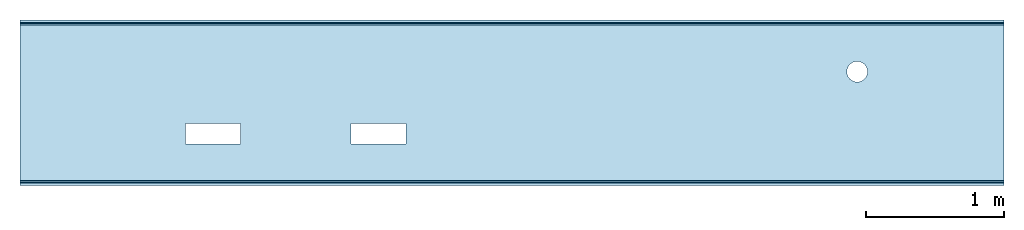
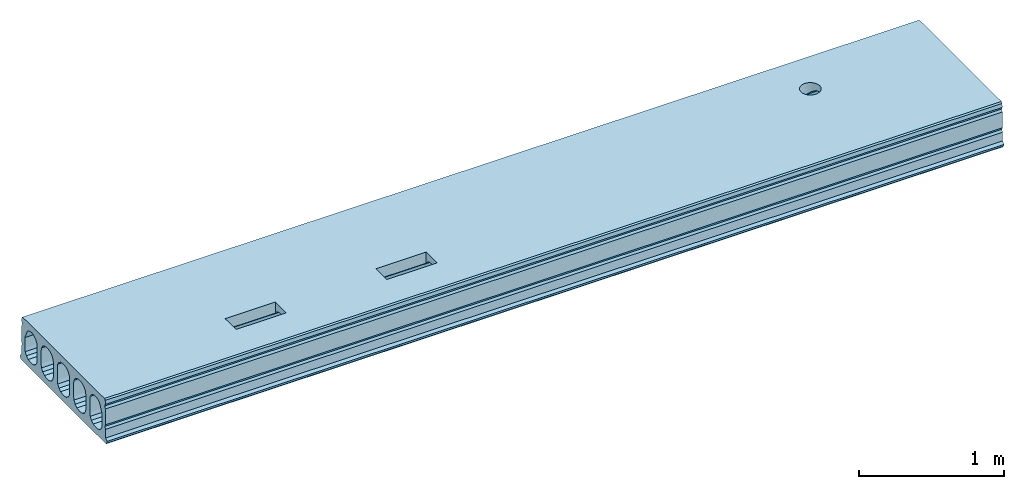
# One storey: 1 slab.
"""IFC2X3 building model written with IfcOpenShell, lengths in millimetres."""

from ifc_helpers import new_model, si_unit, frame, origin_with_axes, place, context, subcontext, project, spatial, faceted_brep, material, type_object, element, save


model = new_model("IFC2X3")

# Units and contexts
model_context = context("Model", 3, precision=1e-05, world=origin_with_axes())
body_context = subcontext(model_context, "Body", "Model", "MODEL_VIEW")
ifc_project = project(units=[si_unit("LENGTHUNIT", "METRE", prefix="MILLI"), si_unit("AREAUNIT", "SQUARE_METRE"), si_unit("VOLUMEUNIT", "CUBIC_METRE"), si_unit("MASSUNIT", "GRAM", prefix="KILO"), si_unit("TIMEUNIT", "SECOND"), si_unit("PLANEANGLEUNIT", "RADIAN"), si_unit("SOLIDANGLEUNIT", "STERADIAN"), si_unit("THERMODYNAMICTEMPERATUREUNIT", "DEGREE_CELSIUS"), si_unit("LUMINOUSINTENSITYUNIT", "LUMEN")], contexts=[model_context])

# Site, building, storey
site_placement = place(None, origin_with_axes())
site = spatial("IfcSite", under=ifc_project, at=site_placement, CompositionType="ELEMENT")
building_placement = place(site_placement, origin_with_axes())
building = spatial("IfcBuilding", under=site, at=building_placement, Name="Undefined", CompositionType="ELEMENT")
storey_placement = place(building_placement, origin_with_axes())
storey = spatial("IfcBuildingStorey", under=building, at=storey_placement, Name="Undefined", CompositionType="ELEMENT", Elevation=0.0)

# Slab
ifc_material = material(Name="CONCRETE/Concrete_Undefined")
slab_type = type_object("IfcSlabType", Name="O37", PredefinedType="NOTDEFINED")
slab_placement = place(storey_placement, frame((0.0, 0.0, 195.0), z_axis=(0.0, 0.0, 1.0), x_axis=(1.0, 0.0, 0.0)))
element("IfcSlab", 1, at=slab_placement, inside=storey, type_object=slab_type, material=ifc_material, ObjectType="O37", PredefinedType="FLOOR", context=body_context, shape_type="Brep", body=[
    faceted_brep([(6147.44443697168, 205.488596031375, 185.0), (6147.44443697168, 205.488596031375, 128.326868937679), (6139.95190528383, 187.400024414064, 124.728828334763), (6139.95190528383, 187.400024414064, 185.0), (6138.26279763535, 185.198736469103, 124.290964938347), (6128.03300858899, 171.867015825073, 115.382993997298), (6128.03300858899, 171.867015825073, 185.0), (6113.69748971645, 160.866985307493, 108.033008588991), (6112.5, 159.948119130231, 106.657828172982), (6112.5, 159.948119130231, 185.0), (6094.41142838269, 152.455587442384, 95.4444620719961), (6094.41142838269, 152.455587442384, 185.0), (6075.0, 149.900024414064, 91.6197917169577), (6075.0, 149.900024414064, 185.0), (6055.58857161731, 152.455587442384, 95.444462071996), (6055.58857161731, 152.455587442384, 185.0), (6037.5, 159.948119130231, 106.657828172982), (6037.5, 159.948119130231, 185.0), (6036.30251028355, 160.866985307493, 108.033008588991), (6021.96699141101, 171.867015825073, 115.382993997298), (6021.96699141101, 171.867015825073, 185.0), (6011.73720236465, 185.198736469103, 124.290964938347), (6010.04809471617, 187.400024414064, 124.728828334763), (6010.04809471617, 187.400024414064, 185.0), (6002.55556302832, 205.488596031375, 128.326868937679), (6002.55556302832, 205.488596031375, 185.0), (6001.44818149118, 213.899993896484, 130.0), (6000.0, 224.900024414064, 130.0), (6000.0, 224.900024414064, 185.0), (6001.18486846057, 233.899993896484, 130.0), (6002.55556302832, 244.311452796753, 127.929032062272), (6002.55556302832, 244.311452796753, 185.0), (6010.04809471617, 262.601251323866, 124.290964938347), (6010.04809471617, 262.400024414064, 185.0), (6021.96699141101, 277.933033003055, 114.04659593907), (6021.96699141101, 277.933033003055, 185.0), (6033.6959799953, 286.933002485475, 108.033008588991), (6037.5, 289.851929697897, 103.66452530208), (6037.5, 289.851929697897, 185.0), (6055.58857161731, 297.344461385744, 92.451159201094), (6055.58857161731, 297.344461385744, 185.0), (6075.0, 299.900024414064, 88.6264888460557), (6075.0, 299.900024414064, 185.0), (6094.41142838269, 297.344461385744, 92.451159201094), (6094.41142838269, 297.344461385744, 185.0), (6112.5, 289.851929697897, 103.66452530208), (6112.5, 289.851929697897, 185.0), (6116.3040200047, 286.933002485475, 108.033008588991), (6128.03300858899, 277.933033003055, 114.04659593907), (6128.03300858899, 277.933033003055, 185.0), (6139.95190528383, 262.601251323866, 124.290964938347), (6139.95190528383, 262.400024414064, 185.0), (6147.44443697168, 244.311452796753, 127.929032062272), (6147.44443697168, 244.311452796753, 185.0), (6148.81513153943, 233.899993896484, 130.0), (6150.0, 224.900024414064, 130.0), (6150.0, 224.900024414064, 185.0), (6148.55181850882, 213.899993896484, 130.0), (6147.44443697168, 205.488596031375, -128.326868937679), (6147.44443697168, 205.488596031375, -185.000000000007), (6139.95190528383, 187.400024414064, -185.000000000007), (6139.95190528383, 187.400024414064, -124.728828334763), (6128.03300858899, 171.867015825073, -185.000000000007), (6128.03300858899, 171.867015825073, -115.382993997298), (6138.26279763535, 185.198736469103, -124.290964938347), (6112.5, 159.948119130231, -185.000000000007), (6112.5, 159.948119130231, -106.657828172982), (6113.69748971645, 160.866985307493, -108.033008588991), (6094.41142838269, 152.455587442384, -185.000000000007), (6094.41142838269, 152.455587442384, -95.4444620719961), (6075.0, 149.900024414064, -185.000000000007), (6075.0, 149.900024414064, -91.6197917169577), (6055.58857161731, 152.455587442384, -185.000000000007), (6055.58857161731, 152.455587442384, -95.444462071996), (6037.5, 159.948119130231, -185.000000000007), (6037.5, 159.948119130231, -106.657828172982), (6021.96699141101, 171.867015825073, -185.000000000007), (6021.96699141101, 171.867015825073, -115.382993997298), (6036.30251028355, 160.866985307493, -108.033008588991), (6010.04809471617, 187.400024414064, -185.000000000007), (6010.04809471617, 187.400024414064, -124.728828334763), (6011.73720236465, 185.198736469103, -124.290964938347), (6002.55556302832, 205.488596031375, -185.000000000007), (6002.55556302832, 205.488596031375, -128.326868937679), (6000.0, 224.900024414064, -185.000000000007), (6000.0, 224.900024414064, -130.0), (6001.44818149118, 213.899993896484, -130.0), (6001.18486846057, 233.899993896484, -130.0), (6002.55556302832, 244.311452796753, -185.000000000007), (6002.55556302832, 244.311452796753, -127.929032062272), (6010.04809471617, 262.400024414064, -185.000000000007), (6010.04809471617, 262.601251323866, -124.290964938346), (6021.96699141101, 277.933033003055, -185.000000000007), (6021.96699141101, 277.933033003055, -114.04659593907), (6033.6959799953, 286.933002485475, -108.033008588991), (6037.5, 289.851929697897, -185.000000000007), (6037.5, 289.851929697897, -103.66452530208), (6055.58857161731, 297.344461385744, -185.000000000007), (6055.58857161731, 297.344461385744, -92.4511592010941), (6075.0, 299.900024414064, -185.000000000007), (6075.0, 299.900024414064, -88.6264888460556), (6094.41142838269, 297.344461385744, -185.000000000007), (6094.41142838269, 297.344461385744, -92.4511592010941), (6112.5, 289.851929697897, -185.000000000007), (6112.5, 289.851929697897, -103.66452530208), (6116.3040200047, 286.933002485475, -108.033008588991), (6128.03300858899, 277.933033003055, -185.000000000007), (6128.03300858899, 277.933033003055, -114.04659593907), (6139.95190528383, 262.400024414064, -185.000000000007), (6139.95190528383, 262.601251323866, -124.290964938346), (6147.44443697168, 244.311452796753, -185.000000000007), (6147.44443697168, 244.311452796753, -127.929032062272), (6148.81513153943, 233.899993896484, -130.0), (6150.0, 224.900024414064, -185.000000000007), (6150.0, 224.900024414064, -130.0), (6148.55181850882, 213.899993896484, -130.0), (0.0, 486.522610075289, -124.281182669233), (0.0, 457.797747535099, -130.0), (7140.0, 457.797747535099, -130.0), (7140.0, 486.522610075289, -124.281182669233), (0.0, 510.866879502976, -107.99686058793), (7140.0, 510.866879502976, -107.99686058793), (0.0, 527.118011020616, -83.6304221117848), (7140.0, 527.118011020616, -83.6304221117848), (0.0, 532.797677893067, -54.8977928580379), (7140.0, 532.797677893067, -54.8977928580379), (0.0, 532.679992675781, 31.4599990844727), (7140.0, 532.679992675781, 31.4599990844727), (0.0, 502.793657291788, 96.4867460243383), (7140.0, 502.793657291788, 96.4867460243383), (0.0, 497.748154577112, 104.990086010811), (7140.0, 497.748154577112, 104.990086010811), (0.0, 491.04510108642, 112.258714662094), (7140.0, 491.04510108642, 112.258714662094), (0.0, 482.977400012167, 117.97501485941), (7140.0, 482.977400012167, 117.97501485941), (0.0, 473.897585524593, 121.889201548954), (7140.0, 473.897585524593, 121.889201548954), (0.0, 454.767801659068, 127.855072874815), (7140.0, 454.767801659068, 127.855072874815), (0.0, 451.318187306564, 128.789447027908), (7140.0, 451.318187306564, 128.789447027908), (0.0, 447.807870775633, 129.460693697647), (7140.0, 447.807870775633, 129.460693697647), (0.0, 444.256892566065, 129.864980717153), (7140.0, 444.256892566065, 129.864980717153), (0.0, 440.685525316365, 130.0), (7140.0, 440.685525316365, 130.0), (0.0, 437.899993896484, 130.0), (7140.0, 437.899993896484, 130.0), (0.0, 409.198736469103, 124.290964938347), (7140.0, 409.198736469103, 124.290964938347), (0.0, 384.866985307493, 108.033008588991), (7140.0, 384.866985307493, 108.033008588991), (0.0, 368.609028958138, 83.7012574273817), (7140.0, 368.609028958138, 83.7012574273817), (0.0, 362.899993896484, 55.0), (7140.0, 362.899993896484, 55.0), (0.0, 362.899993896484, -55.0), (7140.0, 362.899993896484, -55.0), (0.0, 368.609028958138, -83.7012574273817), (7140.0, 368.609028958138, -83.7012574273817), (0.0, 384.866985307493, -108.033008588991), (7140.0, 384.866985307493, -108.033008588991), (0.0, 409.198736469103, -124.290964938347), (7140.0, 409.198736469103, -124.290964938347), (0.0, 437.899993896484, -130.0), (7140.0, 437.899993896484, -130.0), (7140.0, 286.933002485475, 108.033008588991), (7140.0, 262.601251323866, 124.290964938347), (7140.0, 233.899993896484, 130.0), (0.0, 213.899993896484, -130.0), (0.0, 185.198736469103, -124.290964938347), (0.0, 160.866985307493, -108.033008588991), (7140.0, 185.198736469103, -124.290964938347), (7140.0, 213.899993896484, -130.0), (7140.0, 160.866985307493, -108.033008588991), (0.0, 144.609028958138, -83.7012574273817), (7140.0, 144.609028958138, -83.7012574273817), (0.0, 138.899993896484, -55.0), (7140.0, 138.899993896484, -55.0), (0.0, 138.899993896484, 55.0), (7140.0, 138.899993896484, 55.0), (0.0, 144.609028958138, 83.7012574273817), (7140.0, 144.609028958138, 83.7012574273817), (0.0, 262.601251323866, 124.290964938347), (0.0, 286.933002485475, 108.033008588991), (0.0, 233.899993896484, 130.0), (0.0, 213.899993896484, 130.0), (0.0, 185.198736469103, 124.290964938347), (0.0, 160.866985307493, 108.033008588991), (7140.0, 160.866985307493, 108.033008588991), (7140.0, 185.198736469103, 124.290964938347), (7140.0, 213.899993896484, 130.0), (0.0, 303.190958834831, 83.7012574273817), (7140.0, 303.190958834831, 83.7012574273817), (0.0, 308.899993896484, 55.0), (7140.0, 308.899993896484, 55.0), (0.0, 308.899993896484, -55.0), (7140.0, 308.899993896484, -55.0), (0.0, 303.190958834831, -83.7012574273817), (7140.0, 303.190958834831, -83.7012574273817), (0.0, 262.601251323866, -124.290964938346), (0.0, 233.899993896484, -130.0), (0.0, 286.933002485475, -108.033008588991), (7140.0, 286.933002485475, -108.033008588991), (7140.0, 262.601251323866, -124.290964938346), (7140.0, 233.899993896484, -130.0), (0.0, 38.6012589532606, -124.290964938347), (0.0, 9.90000152587889, -130.0), (7140.0, 9.90000152587889, -130.0), (7140.0, 38.6012589532606, -124.290964938347), (0.0, 62.93301011487, -108.033008588991), (7140.0, 62.93301011487, -108.033008588991), (0.0, 79.1909664642254, -83.7012574273817), (7140.0, 79.1909664642254, -83.7012574273817), (0.0, 84.9000015258789, -55.0), (7140.0, 84.9000015258789, -55.0), (0.0, 84.9000015258789, 55.0), (7140.0, 84.9000015258789, 55.0), (0.0, 79.1909664642254, 83.7012574273817), (7140.0, 79.1909664642254, 83.7012574273817), (0.0, 62.93301011487, 108.033008588991), (7140.0, 62.93301011487, 108.033008588991), (0.0, 38.6012589532606, 124.290964938347), (7140.0, 38.6012589532606, 124.290964938347), (0.0, 9.90000152587889, 130.0), (7140.0, 9.90000152587889, 130.0), (0.0, -10.0999984741211, 130.0), (7140.0, -10.0999984741211, 130.0), (0.0, -38.8012559015028, 124.290964938347), (7140.0, -38.8012559015028, 124.290964938347), (0.0, -63.1330070631122, 108.033008588991), (7140.0, -63.1330070631122, 108.033008588991), (0.0, -79.3909634124676, 83.7012574273817), (7140.0, -79.3909634124676, 83.7012574273817), (0.0, -85.0999984741211, 55.0), (7140.0, -85.0999984741211, 55.0), (0.0, -85.0999984741211, -55.0), (7140.0, -85.0999984741211, -55.0), (0.0, -79.3909634124676, -83.7012574273817), (7140.0, -79.3909634124676, -83.7012574273817), (0.0, -63.1330070631121, -108.033008588991), (7140.0, -63.1330070631121, -108.033008588991), (0.0, -38.8012559015028, -124.290964938347), (7140.0, -38.8012559015028, -124.290964938347), (0.0, -10.0999984741211, -130.0), (7140.0, -10.0999984741211, -130.0), (0.0, -287.133014692507, 108.033008588991), (0.0, -262.801263530897, 124.290964938347), (1200.0, -262.801263530897, 124.290964938347), (1200.0, -287.133014692507, 108.033008588991), (0.0, -234.100006103516, 130.0), (1200.0, -234.100006103516, 130.0), (0.0, -214.100006103516, 130.0), (1200.0, -214.100006103516, 130.0), (0.0, -185.398748676134, 124.290964938347), (1200.0, -185.398748676134, 124.290964938347), (1600.0, -185.398748676134, 124.290964938347), (1600.0, -161.066997514525, 108.033008588991), (2400.0, -161.066997514525, 108.033008588991), (2400.0, -185.398748676134, 124.290964938347), (1600.0, -214.100006103516, 130.0), (2400.0, -214.100006103516, 130.0), (1600.0, -234.100006103516, 130.0), (2400.0, -234.100006103516, 130.0), (1600.0, -262.801263530897, 124.290964938347), (2400.0, -262.801263530897, 124.290964938347), (1600.0, -287.133014692507, 108.033008588991), (2400.0, -287.133014692507, 108.033008588991), (0.0, 586.859985351563, -185.0), (0.0, 596.890014648438, -170.960006713867), (7140.0, 596.890014648438, -170.960006713867), (7140.0, 586.859985351563, -185.0), (0.0, 599.900024414063, -155.0), (7140.0, 599.900024414063, -155.0), (0.0, 581.719970703125, -137.149993896484), (7140.0, 581.719970703125, -137.149993896484), (0.0, 580.630004882813, -65.7099990844727), (7140.0, 580.630004882813, -65.7099990844727), (0.0, 570.950012207031, -46.7700004577637), (7140.0, 570.950012207031, -46.7700004577637), (0.0, 580.049987792969, -27.5400009155273), (7140.0, 580.049987792969, -27.5400009155273), (0.0, 577.539978027344, 103.709999084473), (7140.0, 577.539978027344, 103.709999084473), (0.0, 567.849975585938, 122.650001525879), (7140.0, 567.849975585938, 122.650001525879), (0.0, 576.950012207031, 141.880004882813), (7140.0, 576.950012207031, 141.880004882813), (0.0, 575.440002441406, 174.970001220703), (7140.0, 575.440002441406, 174.970001220703), (0.0, 565.25, 185.0), (7140.0, 565.25, 185.0), (0.0, -597.099975585938, -170.960006713867), (0.0, -587.070007324219, -185.0), (7140.0, -587.070007324219, -185.0), (7140.0, -597.099975585938, -170.960006713867), (0.0, -600.099975585938, -155.0), (7140.0, -600.099975585938, -155.0), (0.0, -581.919982910156, -137.149993896484), (7140.0, -581.919982910156, -137.149993896484), (0.0, -580.070007324219, -65.4400024414063), (7140.0, -580.070007324219, -65.4400024414063), (0.0, -570.739990234375, -46.5400009155273), (7140.0, -570.739990234375, -46.5400009155273), (0.0, -579.840026855469, -27.5400009155273), (7140.0, -579.840026855469, -27.5400009155273), (0.0, -577.330017089844, 103.709999084473), (7140.0, -577.330017089844, 103.709999084473), (0.0, -567.640014648438, 122.650001525879), (7140.0, -567.640014648438, 122.650001525879), (0.0, -576.739990234375, 141.880004882813), (7140.0, -576.739990234375, 141.880004882813), (0.0, -575.22998046875, 174.970001220703), (7140.0, -575.22998046875, 174.970001220703), (0.0, -565.039978027344, 185.0), (7140.0, -565.039978027344, 185.0), (2400.0, -300.099975585944, 185.0), (2400.0, -150.099975585944, 185.0), (2800.0, -150.099975585944, 185.0), (2800.0, -300.099975585944, 185.0), (1200.0, -300.099975585931, 185.0), (1200.0, -150.099975585931, 185.0), (1600.0, -150.099975585931, 185.0), (1600.0, -300.099975585931, 185.0), (1600.0, -300.099975585931, 88.6265801916337), (1200.0, -300.099975585931, 88.6265801916337), (1600.0, -150.099975585931, 91.6197003713797), (1200.0, -150.099975585931, 91.6197003713797), (1200.0, -161.066997514525, 108.033008588991), (0.0, -161.066997514525, 108.033008588991), (0.0, -139.100006103516, -55.0), (0.0, -144.809041165169, -83.7012574273817), (7140.0, -144.809041165169, -83.7012574273817), (7140.0, -139.100006103516, -55.0), (0.0, -139.100006103516, 55.0), (7140.0, -139.100006103516, 55.0), (0.0, -144.809041165169, 83.7012574273817), (7140.0, -144.809041165169, 83.7012574273817), (7140.0, -262.801263530897, 124.290964938347), (7140.0, -287.133014692507, 108.033008588991), (2800.0, -287.133014692507, 108.033008588991), (2800.0, -262.801263530897, 124.290964938347), (7140.0, -234.100006103516, 130.0), (2800.0, -234.100006103516, 130.0), (7140.0, -214.100006103516, 130.0), (2800.0, -214.100006103516, 130.0), (7140.0, -185.398748676134, 124.290964938347), (2800.0, -185.398748676134, 124.290964938347), (7140.0, -161.066997514525, 108.033008588991), (2800.0, -161.066997514525, 108.033008588991), (2800.0, -150.099975585944, 91.6197003713987), (2400.0, -150.099975585944, 91.6197003713987), (2400.0, -300.099975585944, 88.6265801916145), (2800.0, -300.099975585944, 88.6265801916145), (7140.0, -303.390971041862, 83.7012574273817), (0.0, -303.390971041862, 83.7012574273817), (0.0, -309.100006103516, 55.0), (7140.0, -309.100006103516, 55.0), (0.0, -309.100006103516, -55.0), (7140.0, -309.100006103516, -55.0), (0.0, -303.390971041862, -83.7012574273817), (7140.0, -303.390971041862, -83.7012574273817), (0.0, -161.066997514525, -108.033008588991), (0.0, -185.398748676134, -124.290964938346), (1200.0, -185.398748676134, -124.290964938346), (1200.0, -161.066997514525, -108.033008588991), (0.0, -214.100006103516, -130.0), (1200.0, -214.100006103516, -130.0), (0.0, -234.100006103516, -130.0), (0.0, -262.801263530897, -124.290964938347), (1200.0, -262.801263530897, -124.290964938347), (1200.0, -234.100006103516, -130.0), (0.0, -287.133014692507, -108.033008588991), (1200.0, -287.133014692507, -108.033008588991), (1600.0, -300.099975585931, -88.6265801916337), (1600.0, -300.099975585931, -184.999999999992), (1200.0, -300.099975585931, -184.999999999992), (1200.0, -300.099975585931, -88.6265801916337), (1600.0, -262.801263530897, -124.290964938347), (1600.0, -287.133014692507, -108.033008588991), (2400.0, -287.133014692507, -108.033008588991), (2400.0, -262.801263530897, -124.290964938347), (1600.0, -234.100006103516, -130.0), (2400.0, -234.100006103516, -130.0), (1600.0, -214.100006103516, -130.0), (2400.0, -214.100006103516, -130.0), (1600.0, -185.398748676134, -124.290964938346), (2400.0, -185.398748676134, -124.290964938346), (1600.0, -161.066997514525, -108.033008588991), (2400.0, -161.066997514525, -108.033008588991), (1600.0, -150.099975585931, -91.6197003713797), (1600.0, -150.099975585931, -184.999999999992), (1200.0, -150.099975585931, -91.6197003713797), (1200.0, -150.099975585931, -184.999999999992), (0.0, -409.398748676134, -124.290964938346), (0.0, -385.066997514525, -108.033008588991), (0.0, -368.809041165169, -83.7012574273817), (0.0, -363.100006103516, -55.0), (0.0, -363.100006103516, 55.0), (0.0, -368.809041165169, 83.7012574273817), (0.0, -385.066997514525, 108.033008588991), (0.0, -409.398748676134, 124.290964938347), (0.0, -438.100006103516, 130.0), (0.0, -440.905458547625, 130.0), (0.0, -444.476831797178, 129.864952985487), (0.0, -448.027807676442, 129.460583243007), (0.0, -451.538105311693, 128.789200270557), (0.0, -454.987676156985, 127.85463857272), (0.0, -474.113683490167, 121.888653832883), (0.0, -483.190791183214, 117.975054935726), (0.0, -491.256055131865, 112.260017067295), (0.0, -497.957099488949, 104.993233396137), (0.0, -503.001151916536, 96.4921937240296), (0.0, -526.058454074776, 46.3241102051714), (0.0, -529.022615447613, 38.8403279823523), (0.0, -531.167660399297, 31.0819756342013), (0.0, -532.468880586419, 23.1384200683711), (0.0, -532.911287514118, 15.1011615113052), (0.0, -533.002319524285, -54.9024708467264), (0.0, -527.321307017782, -83.6336648774161), (0.0, -511.069862086386, -107.998515608949), (0.0, -486.72616515099, -124.281630576477), (0.0, -458.002382937217, -130.0), (0.0, -438.100006103516, -130.0), (7140.0, -438.100006103516, -130.0), (7140.0, -409.398748676134, -124.290964938346), (7140.0, -385.066997514525, -108.033008588991), (7140.0, -368.809041165169, -83.7012574273817), (7140.0, -363.100006103516, -55.0), (7140.0, -363.100006103516, 55.0), (7140.0, -368.809041165169, 83.7012574273817), (7140.0, -385.066997514525, 108.033008588991), (7140.0, -409.398748676134, 124.290964938347), (7140.0, -438.100006103516, 130.0), (7140.0, -440.905458547625, 130.0), (7140.0, -444.476831797178, 129.864952985487), (7140.0, -448.027807676442, 129.460583243007), (7140.0, -451.538105311693, 128.789200270557), (7140.0, -454.987676156985, 127.85463857272), (7140.0, -474.113683490167, 121.888653832883), (7140.0, -483.190791183214, 117.975054935726), (7140.0, -491.256055131865, 112.260017067295), (7140.0, -497.957099488949, 104.993233396137), (7140.0, -503.001151916536, 96.4921937240296), (7140.0, -526.058454074776, 46.3241102051714), (7140.0, -529.022615447613, 38.8403279823523), (7140.0, -531.167660399297, 31.0819756342013), (7140.0, -532.468880586419, 23.1384200683711), (7140.0, -532.911287514118, 15.1011615113052), (7140.0, -533.002319524285, -54.9024708467264), (7140.0, -527.321307017782, -83.6336648774161), (7140.0, -511.069862086386, -107.998515608949), (7140.0, -486.72616515099, -124.281630576477), (7140.0, -458.002382937217, -130.0), (7140.0, -262.801263530897, -124.290964938347), (7140.0, -287.133014692507, -108.033008588991), (7140.0, -161.066997514525, -108.033008588991), (7140.0, -185.398748676134, -124.290964938346), (7140.0, -214.100006103516, -130.0), (7140.0, -234.100006103516, -130.0), (2800.0, -185.398748676134, -124.290964938346), (2800.0, -214.100006103516, -130.0), (2800.0, -234.100006103516, -130.0), (2800.0, -262.801263530897, -124.290964938347), (2800.0, -287.133014692507, -108.033008588991), (2400.0, -300.099975585944, -88.6265801916146), (2800.0, -300.099975585944, -88.6265801916146), (2800.0, -300.099975585944, -185.000000000018), (2400.0, -300.099975585944, -185.000000000018), (2400.0, -150.099975585944, -185.000000000018), (2400.0, -150.099975585944, -91.6197003713987), (2800.0, -150.099975585944, -91.6197003713987), (2800.0, -161.066997514525, -108.033008588991), (2800.0, -150.099975585944, -185.000000000018)], [[[0, 1, 2, 3]], [[3, 2, 4, 5, 6]], [[6, 5, 7, 8, 9]], [[9, 8, 10, 11]], [[11, 10, 12, 13]], [[13, 12, 14, 15]], [[15, 14, 16, 17]], [[17, 16, 18, 19, 20]], [[20, 19, 21, 22, 23]], [[23, 22, 24, 25]], [[25, 24, 26, 27, 28]], [[28, 27, 29, 30, 31]], [[31, 30, 32, 33]], [[33, 32, 34, 35]], [[35, 34, 36, 37, 38]], [[38, 37, 39, 40]], [[40, 39, 41, 42]], [[42, 41, 43, 44]], [[44, 43, 45, 46]], [[46, 45, 47, 48, 49]], [[49, 48, 50, 51]], [[51, 50, 52, 53]], [[53, 52, 54, 55, 56]], [[56, 55, 57, 1, 0]], [[58, 59, 60, 61]], [[61, 60, 62, 63, 64]], [[63, 62, 65, 66, 67]], [[66, 65, 68, 69]], [[69, 68, 70, 71]], [[71, 70, 72, 73]], [[73, 72, 74, 75]], [[75, 74, 76, 77, 78]], [[77, 76, 79, 80, 81]], [[80, 79, 82, 83]], [[83, 82, 84, 85, 86]], [[87, 85, 84, 88, 89]], [[89, 88, 90, 91]], [[91, 90, 92, 93]], [[94, 93, 92, 95, 96]], [[96, 95, 97, 98]], [[98, 97, 99, 100]], [[100, 99, 101, 102]], [[102, 101, 103, 104]], [[105, 104, 103, 106, 107]], [[107, 106, 108, 109]], [[109, 108, 110, 111]], [[112, 111, 110, 113, 114]], [[114, 113, 59, 58, 115]], [[116, 117, 118, 119]], [[120, 116, 119, 121]], [[122, 120, 121, 123]], [[124, 122, 123, 125]], [[126, 124, 125, 127]], [[128, 126, 127, 129]], [[130, 128, 129, 131]], [[132, 130, 131, 133]], [[134, 132, 133, 135]], [[136, 134, 135, 137]], [[138, 136, 137, 139]], [[140, 138, 139, 141]], [[142, 140, 141, 143]], [[144, 142, 143, 145]], [[146, 144, 145, 147]], [[148, 146, 147, 149]], [[150, 148, 149, 151]], [[152, 150, 151, 153]], [[154, 152, 153, 155]], [[156, 154, 155, 157]], [[158, 156, 157, 159]], [[160, 158, 159, 161]], [[162, 160, 161, 163]], [[164, 162, 163, 165]], [[166, 164, 165, 167]], [[117, 166, 167, 118]], [[47, 168, 169, 50, 48]], [[50, 169, 170, 54, 52]], [[83, 86, 171, 172, 81, 80]], [[81, 172, 173, 78, 77]], [[61, 64, 174, 175, 115, 58]], [[67, 176, 174, 64, 63]], [[69, 71, 73, 75, 78, 173, 177, 178, 176, 67, 66]], [[177, 179, 180, 178]], [[179, 181, 182, 180]], [[181, 183, 184, 182]], [[32, 185, 186, 36, 34]], [[29, 187, 185, 32, 30]], [[188, 187, 29, 27, 26]], [[189, 188, 26, 24, 22, 21]], [[190, 189, 21, 19, 18]], [[191, 184, 183, 190, 18, 16, 14, 12, 10, 8, 7]], [[192, 191, 7, 5, 4]], [[193, 192, 4, 2, 1, 57]], [[170, 193, 57, 55, 54]], [[43, 41, 39, 37, 36, 186, 194, 195, 168, 47, 45]], [[194, 196, 197, 195]], [[196, 198, 199, 197]], [[198, 200, 201, 199]], [[202, 203, 87, 89, 91]], [[204, 202, 91, 93, 94]], [[205, 201, 200, 204, 94, 96, 98, 100, 102, 104, 105]], [[206, 205, 105, 107, 109]], [[207, 206, 109, 111, 112]], [[175, 207, 112, 114, 115]], [[87, 203, 171, 86, 85]], [[208, 209, 210, 211]], [[212, 208, 211, 213]], [[214, 212, 213, 215]], [[216, 214, 215, 217]], [[218, 216, 217, 219]], [[220, 218, 219, 221]], [[222, 220, 221, 223]], [[224, 222, 223, 225]], [[226, 224, 225, 227]], [[228, 226, 227, 229]], [[230, 228, 229, 231]], [[232, 230, 231, 233]], [[234, 232, 233, 235]], [[236, 234, 235, 237]], [[238, 236, 237, 239]], [[240, 238, 239, 241]], [[242, 240, 241, 243]], [[244, 242, 243, 245]], [[246, 244, 245, 247]], [[209, 246, 247, 210]], [[248, 249, 250, 251]], [[249, 252, 253, 250]], [[252, 254, 255, 253]], [[254, 256, 257, 255]], [[258, 259, 260, 261]], [[262, 258, 261, 263]], [[264, 262, 263, 265]], [[266, 264, 265, 267]], [[268, 266, 267, 269]], [[270, 271, 272, 273]], [[271, 274, 275, 272]], [[274, 276, 277, 275]], [[276, 278, 279, 277]], [[278, 280, 281, 279]], [[280, 282, 283, 281]], [[282, 284, 285, 283]], [[284, 286, 287, 285]], [[286, 288, 289, 287]], [[288, 290, 291, 289]], [[290, 292, 293, 291]], [[294, 295, 296, 297]], [[298, 294, 297, 299]], [[300, 298, 299, 301]], [[302, 300, 301, 303]], [[304, 302, 303, 305]], [[306, 304, 305, 307]], [[308, 306, 307, 309]], [[310, 308, 309, 311]], [[312, 310, 311, 313]], [[314, 312, 313, 315]], [[316, 314, 315, 317]], [[292, 316, 317, 293], [3, 6, 9, 11, 13, 15, 17, 20, 23, 25, 28, 31, 33, 35, 38, 40, 42, 44, 46, 49, 51, 53, 56, 0], [318, 319, 320, 321], [322, 323, 324, 325]], [[325, 326, 327, 322]], [[324, 328, 259, 258, 262, 264, 266, 268, 326, 325]], [[323, 329, 328, 324]], [[322, 327, 251, 250, 253, 255, 257, 330, 329, 323]], [[256, 331, 330, 257]], [[332, 333, 334, 335]], [[336, 332, 335, 337]], [[338, 336, 337, 339]], [[340, 341, 342, 343]], [[344, 340, 343, 345]], [[346, 344, 345, 347]], [[348, 346, 347, 349]], [[350, 348, 349, 351]], [[260, 259, 328, 329, 330, 331, 338, 339, 350, 351, 352, 353]], [[319, 353, 352, 320]], [[318, 354, 269, 267, 265, 263, 261, 260, 353, 319]], [[321, 355, 354, 318]], [[320, 352, 351, 349, 347, 345, 343, 342, 355, 321]], [[341, 356, 357, 248, 251, 327, 326, 268, 269, 354, 355, 342]], [[358, 357, 356, 359]], [[360, 358, 359, 361]], [[362, 360, 361, 363]], [[364, 365, 366, 367]], [[365, 368, 369, 366]], [[370, 371, 372, 373]], [[371, 374, 375, 372]], [[376, 377, 378, 379]], [[380, 381, 382, 383]], [[384, 380, 383, 385]], [[386, 384, 385, 387]], [[388, 386, 387, 389]], [[390, 388, 389, 391]], [[392, 393, 377, 376, 381, 380, 384, 386, 388, 390]], [[394, 395, 393, 392]], [[367, 366, 369, 373, 372, 375, 379, 378, 395, 394]], [[368, 370, 373, 369]], [[270, 295, 294, 298, 300, 302, 304, 306, 308, 310, 312, 314, 316, 292, 290, 288, 286, 284, 282, 280, 278, 276, 274, 271], [365, 364, 333, 332, 336, 338, 331, 256, 254, 252, 249, 248, 357, 358, 360, 362, 374, 371, 370, 368], [208, 212, 214, 216, 218, 220, 222, 224, 226, 228, 230, 232, 234, 236, 238, 240, 242, 244, 246, 209], [202, 204, 200, 198, 196, 194, 186, 185, 187, 188, 189, 190, 183, 181, 179, 177, 173, 172, 171, 203], [116, 120, 122, 124, 126, 128, 130, 132, 134, 136, 138, 140, 142, 144, 146, 148, 150, 152, 154, 156, 158, 160, 162, 164, 166, 117], [396, 397, 398, 399, 400, 401, 402, 403, 404, 405, 406, 407, 408, 409, 410, 411, 412, 413, 414, 415, 416, 417, 418, 419, 420, 421, 422, 423, 424, 425]], [[396, 425, 426, 427]], [[397, 396, 427, 428]], [[398, 397, 428, 429]], [[399, 398, 429, 430]], [[400, 399, 430, 431]], [[401, 400, 431, 432]], [[402, 401, 432, 433]], [[403, 402, 433, 434]], [[404, 403, 434, 435]], [[405, 404, 435, 436]], [[406, 405, 436, 437]], [[407, 406, 437, 438]], [[408, 407, 438, 439]], [[409, 408, 439, 440]], [[410, 409, 440, 441]], [[411, 410, 441, 442]], [[412, 411, 442, 443]], [[413, 412, 443, 444]], [[414, 413, 444, 445]], [[415, 414, 445, 446]], [[416, 415, 446, 447]], [[417, 416, 447, 448]], [[418, 417, 448, 449]], [[419, 418, 449, 450]], [[420, 419, 450, 451]], [[421, 420, 451, 452]], [[422, 421, 452, 453]], [[423, 422, 453, 454]], [[424, 423, 454, 455]], [[425, 424, 455, 426]], [[277, 279, 281, 283, 285, 287, 289, 291, 293, 317, 315, 313, 311, 309, 307, 305, 303, 301, 299, 297, 296, 273, 272, 275], [454, 453, 452, 451, 450, 449, 448, 447, 446, 445, 444, 443, 442, 441, 440, 439, 438, 437, 436, 435, 434, 433, 432, 431, 430, 429, 428, 427, 426, 455], [456, 457, 363, 361, 359, 356, 341, 340, 344, 346, 348, 350, 339, 337, 335, 334, 458, 459, 460, 461], [245, 243, 241, 239, 237, 235, 233, 231, 229, 227, 225, 223, 221, 219, 217, 215, 213, 211, 210, 247], [174, 176, 178, 180, 182, 184, 191, 192, 193, 170, 169, 168, 195, 197, 199, 201, 205, 206, 207, 175], [165, 163, 161, 159, 157, 155, 153, 151, 149, 147, 145, 143, 141, 139, 137, 135, 133, 131, 129, 127, 125, 123, 121, 119, 118, 167]], [[460, 459, 462, 463]], [[461, 460, 463, 464]], [[456, 461, 464, 465]], [[457, 456, 465, 466]], [[467, 382, 381, 376, 379, 375, 374, 362, 363, 457, 466, 468]], [[468, 469, 470, 467]], [[391, 389, 387, 385, 383, 382, 467, 470, 471, 472]], [[458, 334, 333, 364, 367, 394, 392, 390, 391, 472, 473, 474]], [[459, 458, 474, 462]], [[473, 475, 469, 468, 466, 465, 464, 463, 462, 474]], [[472, 471, 475, 473]], [[295, 270, 273, 296], [108, 106, 103, 101, 99, 97, 95, 92, 90, 88, 84, 82, 79, 76, 74, 72, 70, 68, 65, 62, 60, 59, 113, 110], [470, 469, 475, 471], [378, 377, 393, 395]]]),
])

save(model, "model.ifc")
